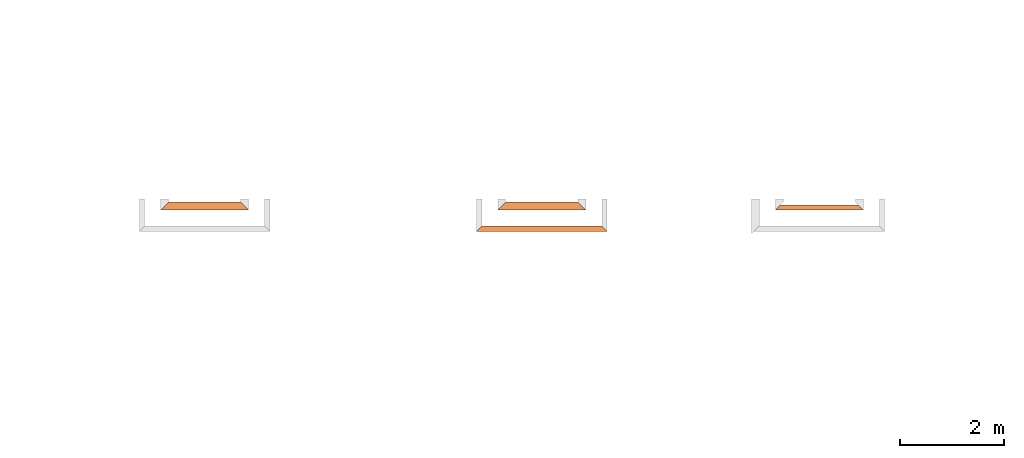
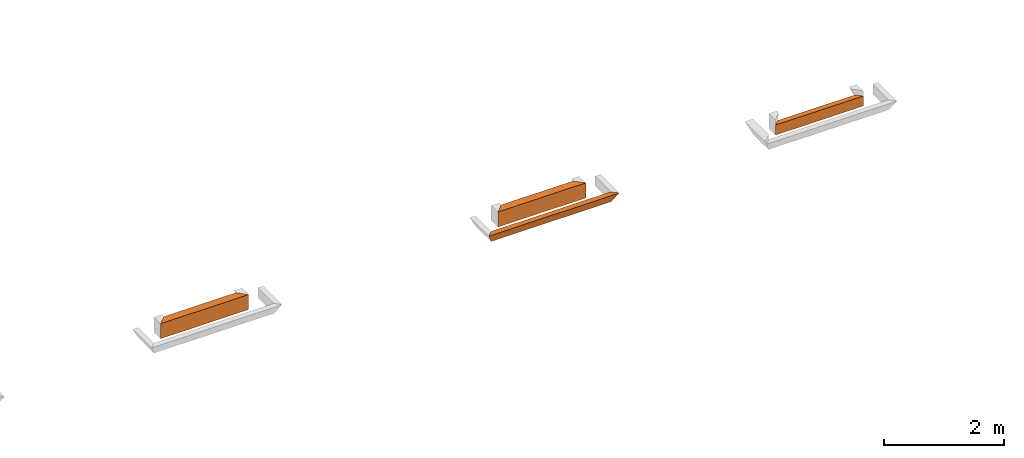
# One storey, part 3 of 8: 4 proxies.
"""IFC4 building model written with IfcOpenShell, lengths in feet."""

from ifc_helpers import new_model, entity, si_unit, converted_unit, derived_unit, direction, frame, origin, place, context, subcontext, project, spatial, type_object, element, save


model = new_model("IFC4")

# Units and contexts
model_context_1 = context("Model", 3, precision=0.0001, world=origin(), true_north=direction((6.12303176911189e-17, 1.0)))
model_context_2 = context("Model", 3, precision=0.0001, world=origin(), true_north=direction((6.12303176911189e-17, 1.0)))
body_context = subcontext(model_context_2, "Body", "Model", "MODEL_VIEW")
ifc_project = project(units=[converted_unit("LENGTHUNIT", "FOOT", entity("IfcRatioMeasure", 0.3048), si_unit("LENGTHUNIT", "METRE"), dimensions=[1, 0, 0, 0, 0, 0, 0]), converted_unit("AREAUNIT", "SQUARE FOOT", entity("IfcRatioMeasure", 0.09290304), si_unit("AREAUNIT", "SQUARE_METRE"), dimensions=[2, 0, 0, 0, 0, 0, 0]), converted_unit("VOLUMEUNIT", "CUBIC FOOT", entity("IfcRatioMeasure", 0.028316846592), si_unit("VOLUMEUNIT", "CUBIC_METRE"), dimensions=[3, 0, 0, 0, 0, 0, 0]), converted_unit("PLANEANGLEUNIT", "DEGREE", entity("IfcRatioMeasure", 0.0174532925199433), si_unit("PLANEANGLEUNIT", "RADIAN"), dimensions=[0, 0, 0, 0, 0, 0, 0]), si_unit("MASSUNIT", "GRAM", prefix="KILO"), derived_unit("MASSDENSITYUNIT", [(si_unit("MASSUNIT", "GRAM", prefix="KILO"), 1), (si_unit("LENGTHUNIT", "METRE"), -3)]), derived_unit("MOMENTOFINERTIAUNIT", [(si_unit("LENGTHUNIT", "METRE"), 4)]), si_unit("TIMEUNIT", "SECOND"), si_unit("FREQUENCYUNIT", "HERTZ"), si_unit("THERMODYNAMICTEMPERATUREUNIT", "DEGREE_CELSIUS"), derived_unit("THERMALTRANSMITTANCEUNIT", [(si_unit("MASSUNIT", "GRAM", prefix="KILO"), 1), (si_unit("THERMODYNAMICTEMPERATUREUNIT", "KELVIN"), -1), (si_unit("TIMEUNIT", "SECOND"), -3)]), derived_unit("VOLUMETRICFLOWRATEUNIT", [(si_unit("LENGTHUNIT", "METRE"), 3), (si_unit("TIMEUNIT", "SECOND"), -1)]), si_unit("ELECTRICCURRENTUNIT", "AMPERE"), si_unit("ELECTRICVOLTAGEUNIT", "VOLT"), si_unit("POWERUNIT", "WATT"), si_unit("FORCEUNIT", "NEWTON"), si_unit("ILLUMINANCEUNIT", "LUX"), si_unit("LUMINOUSFLUXUNIT", "LUMEN"), si_unit("LUMINOUSINTENSITYUNIT", "CANDELA"), derived_unit("USERDEFINED", [(si_unit("MASSUNIT", "GRAM", prefix="KILO"), -1), (si_unit("LENGTHUNIT", "METRE"), -2), (si_unit("TIMEUNIT", "SECOND"), 3), (si_unit("LUMINOUSFLUXUNIT", "LUMEN"), 1)]), derived_unit("LINEARVELOCITYUNIT", [(si_unit("LENGTHUNIT", "METRE"), 1), (si_unit("TIMEUNIT", "SECOND"), -1)]), si_unit("PRESSUREUNIT", "PASCAL"), derived_unit("USERDEFINED", [(si_unit("LENGTHUNIT", "METRE"), -2), (si_unit("MASSUNIT", "GRAM", prefix="KILO"), 1), (si_unit("TIMEUNIT", "SECOND"), -2)]), derived_unit("LINEARFORCEUNIT", [(si_unit("MASSUNIT", "GRAM", prefix="KILO"), 1), (si_unit("LENGTHUNIT", "METRE"), 1), (si_unit("TIMEUNIT", "SECOND"), -2), (si_unit("LENGTHUNIT", "METRE"), -1)]), derived_unit("PLANARFORCEUNIT", [(si_unit("MASSUNIT", "GRAM", prefix="KILO"), 1), (si_unit("LENGTHUNIT", "METRE"), 1), (si_unit("TIMEUNIT", "SECOND"), -2), (si_unit("LENGTHUNIT", "METRE"), -2)])], contexts=[model_context_1])

# Site, building, storey
site_placement = place(None, origin())
site = spatial("IfcSite", under=ifc_project, at=site_placement, CompositionType="ELEMENT")
building_placement = place(site_placement, origin())
building = spatial("IfcBuilding", under=site, at=building_placement, CompositionType="ELEMENT")
storey_placement = place(building_placement, frame((0.0, 0.0, -12.6666666666667)))
storey = spatial("IfcBuildingStorey", under=building, at=storey_placement, Name="BASEMENT", CompositionType="ELEMENT", Elevation=-12.6666666666667)

# Proxies
building_element_proxy_type_1 = type_object("IfcBuildingElementProxyType", PredefinedType="NOTDEFINED")
proxy_1_placement = place(storey_placement, frame((-196.572796069664, 955.897091132648, 11.5833333333333)))
cartesian_point_1 = entity("IfcCartesianPoint", [7.87630257139756, 0.334635416666629, 0.0])
vertex_point_1 = entity("IfcVertexPoint", cartesian_point_1)
cartesian_point_2 = entity("IfcCartesianPoint", [7.87630257139756, 0.334635416666629, 0.669270833333334])
vertex_point_2 = entity("IfcVertexPoint", cartesian_point_2)
ifc_direction_1 = entity("IfcDirection", [0.0, 0.0, 1.0])
edge_curve_1 = entity("IfcEdgeCurve", vertex_point_1, vertex_point_2, entity("IfcTrimmedCurve", entity("IfcLine", cartesian_point_1, entity("IfcVector", ifc_direction_1, 1.0)), [cartesian_point_1], [cartesian_point_2], True, "CARTESIAN"), True)
cartesian_point_3 = entity("IfcCartesianPoint", [8.21093798806413, 0.0, 0.669270833333334])
vertex_point_3 = entity("IfcVertexPoint", cartesian_point_3)
edge_curve_2 = entity("IfcEdgeCurve", vertex_point_2, vertex_point_3, entity("IfcTrimmedCurve", entity("IfcLine", cartesian_point_2, entity("IfcVector", entity("IfcDirection", [0.707106781186488, -0.707106781186608, 0.0]), 1.0)), [cartesian_point_2], [cartesian_point_3], True, "CARTESIAN"), True)
edge_curve_3 = entity("IfcEdgeCurve", vertex_point_3, vertex_point_1, entity("IfcTrimmedCurve", entity("IfcLine", cartesian_point_3, entity("IfcVector", entity("IfcDirection", [-0.408248290463863, 0.408248290463829, -0.816496580927743]), 1.0)), [cartesian_point_3], [cartesian_point_1], True, "CARTESIAN"), True)
cartesian_point_4 = entity("IfcCartesianPoint", [0.334635416666686, 0.33463541666697, 0.0])
vertex_point_4 = entity("IfcVertexPoint", cartesian_point_4)
cartesian_point_5 = entity("IfcCartesianPoint", [0.0, 0.0, 0.669270833333334])
vertex_point_5 = entity("IfcVertexPoint", cartesian_point_5)
edge_curve_4 = entity("IfcEdgeCurve", vertex_point_4, vertex_point_5, entity("IfcTrimmedCurve", entity("IfcLine", cartesian_point_4, entity("IfcVector", entity("IfcDirection", [-0.408248290463863, -0.408248290463829, 0.816496580927743]), 1.0)), [cartesian_point_4], [cartesian_point_5], True, "CARTESIAN"), True)
cartesian_point_6 = entity("IfcCartesianPoint", [0.334635416666686, 0.33463541666697, 0.669270833333334])
vertex_point_6 = entity("IfcVertexPoint", cartesian_point_6)
edge_curve_5 = entity("IfcEdgeCurve", vertex_point_5, vertex_point_6, entity("IfcTrimmedCurve", entity("IfcLine", cartesian_point_5, entity("IfcVector", entity("IfcDirection", [0.707106781186488, 0.707106781186608, 0.0]), 1.0)), [cartesian_point_5], [cartesian_point_6], True, "CARTESIAN"), True)
edge_curve_6 = entity("IfcEdgeCurve", vertex_point_6, vertex_point_4, entity("IfcTrimmedCurve", entity("IfcLine", cartesian_point_6, entity("IfcVector", entity("IfcDirection", [0.0, 0.0, -1.0]), 1.0)), [cartesian_point_6], [cartesian_point_4], True, "CARTESIAN"), True)
ifc_direction_2 = entity("IfcDirection", [-1.0, 0.0, 0.0])
edge_curve_7 = entity("IfcEdgeCurve", vertex_point_1, vertex_point_4, entity("IfcTrimmedCurve", entity("IfcLine", cartesian_point_1, entity("IfcVector", ifc_direction_2, 1.0)), [cartesian_point_1], [cartesian_point_4], True, "CARTESIAN"), True)
cartesian_point_7 = entity("IfcCartesianPoint", [1.33463541666657, 0.33463541666697, 0.669270833333334])
vertex_point_7 = entity("IfcVertexPoint", cartesian_point_7)
ifc_direction_3 = entity("IfcDirection", [1.0, 0.0, 0.0])
edge_curve_8 = entity("IfcEdgeCurve", vertex_point_6, vertex_point_7, entity("IfcTrimmedCurve", entity("IfcLine", cartesian_point_6, entity("IfcVector", ifc_direction_3, 1.0)), [cartesian_point_6], [cartesian_point_7], True, "CARTESIAN"), True)
cartesian_point_8 = entity("IfcCartesianPoint", [2.5846355840587, 0.334635416666856, 0.669270833333334])
vertex_point_8 = entity("IfcVertexPoint", cartesian_point_8)
edge_curve_9 = entity("IfcEdgeCurve", vertex_point_7, vertex_point_8, entity("IfcTrimmedCurve", entity("IfcLine", cartesian_point_7, entity("IfcVector", ifc_direction_3, 1.0)), [cartesian_point_7], [cartesian_point_8], True, "CARTESIAN"), True)
cartesian_point_9 = entity("IfcCartesianPoint", [3.75130225072536, 0.334635416666856, 0.669270833333334])
vertex_point_9 = entity("IfcVertexPoint", cartesian_point_9)
edge_curve_10 = entity("IfcEdgeCurve", vertex_point_8, vertex_point_9, entity("IfcTrimmedCurve", entity("IfcLine", cartesian_point_8, entity("IfcVector", ifc_direction_3, 1.0)), [cartesian_point_8], [cartesian_point_9], True, "CARTESIAN"), True)
cartesian_point_10 = entity("IfcCartesianPoint", [6.87630257139756, 0.334635416666629, 0.669270833333334])
vertex_point_10 = entity("IfcVertexPoint", cartesian_point_10)
edge_curve_11 = entity("IfcEdgeCurve", vertex_point_9, vertex_point_10, entity("IfcTrimmedCurve", entity("IfcLine", cartesian_point_9, entity("IfcVector", ifc_direction_3, 1.0)), [cartesian_point_9], [cartesian_point_10], True, "CARTESIAN"), True)
edge_curve_12 = entity("IfcEdgeCurve", vertex_point_10, vertex_point_2, entity("IfcTrimmedCurve", entity("IfcLine", cartesian_point_10, entity("IfcVector", ifc_direction_3, 1.0)), [cartesian_point_10], [cartesian_point_2], True, "CARTESIAN"), True)
edge_curve_13 = entity("IfcEdgeCurve", vertex_point_3, vertex_point_5, entity("IfcTrimmedCurve", entity("IfcLine", cartesian_point_3, entity("IfcVector", ifc_direction_2, 1.0)), [cartesian_point_3], [cartesian_point_5], True, "CARTESIAN"), True)
element("IfcBuildingElementProxy", 1, at=proxy_1_placement, inside=storey, type_object=building_element_proxy_type_1, PredefinedType="NOTDEFINED", context=body_context, shape_type="AdvancedBrep", body=[
    entity("IfcAdvancedBrep", entity("IfcClosedShell", [entity("IfcAdvancedFace", [entity("IfcFaceOuterBound", entity("IfcEdgeLoop", [entity("IfcOrientedEdge", None, None, edge_curve_1, True), entity("IfcOrientedEdge", None, None, edge_curve_2, True), entity("IfcOrientedEdge", None, None, edge_curve_3, True)]), True)], entity("IfcPlane", entity("IfcAxis2Placement3D", entity("IfcCartesianPoint", [7.87630257139756, 0.334635416666629, 2.0]), entity("IfcDirection", [0.707106781186562, 0.707106781186533, 0.0]), entity("IfcDirection", [-0.707106781186533, 0.707106781186562, 0.0]))), True), entity("IfcAdvancedFace", [entity("IfcFaceOuterBound", entity("IfcEdgeLoop", [entity("IfcOrientedEdge", None, None, edge_curve_4, True), entity("IfcOrientedEdge", None, None, edge_curve_5, True), entity("IfcOrientedEdge", None, None, edge_curve_6, True)]), True)], entity("IfcPlane", entity("IfcAxis2Placement3D", entity("IfcCartesianPoint", [0.334635416666572, 0.334635416666856, 2.0]), entity("IfcDirection", [-0.707106781186548, 0.707106781186548, 0.0]), entity("IfcDirection", [0.707106781186548, 0.707106781186548, 0.0]))), True), entity("IfcAdvancedFace", [entity("IfcFaceOuterBound", entity("IfcEdgeLoop", [entity("IfcOrientedEdge", None, None, edge_curve_7, True), entity("IfcOrientedEdge", None, None, edge_curve_6, False), entity("IfcOrientedEdge", None, None, edge_curve_8, True), entity("IfcOrientedEdge", None, None, edge_curve_9, True), entity("IfcOrientedEdge", None, None, edge_curve_10, True), entity("IfcOrientedEdge", None, None, edge_curve_11, True), entity("IfcOrientedEdge", None, None, edge_curve_12, True), entity("IfcOrientedEdge", None, None, edge_curve_1, False)]), True)], entity("IfcPlane", entity("IfcAxis2Placement3D", cartesian_point_1, entity("IfcDirection", [0.0, 1.0, 0.0]), ifc_direction_2)), True), entity("IfcAdvancedFace", [entity("IfcFaceOuterBound", entity("IfcEdgeLoop", [entity("IfcOrientedEdge", None, None, edge_curve_7, False), entity("IfcOrientedEdge", None, None, edge_curve_3, False), entity("IfcOrientedEdge", None, None, edge_curve_13, True), entity("IfcOrientedEdge", None, None, edge_curve_4, False)]), True)], entity("IfcPlane", entity("IfcAxis2Placement3D", entity("IfcCartesianPoint", [8.37630257139756, -0.165364583333371, 1.0]), entity("IfcDirection", [0.0, -0.894427190999915, -0.447213595499961]), ifc_direction_2)), True), entity("IfcAdvancedFace", [entity("IfcFaceOuterBound", entity("IfcEdgeLoop", [entity("IfcOrientedEdge", None, None, edge_curve_2, False), entity("IfcOrientedEdge", None, None, edge_curve_12, False), entity("IfcOrientedEdge", None, None, edge_curve_11, False), entity("IfcOrientedEdge", None, None, edge_curve_10, False), entity("IfcOrientedEdge", None, None, edge_curve_9, False), entity("IfcOrientedEdge", None, None, edge_curve_8, False), entity("IfcOrientedEdge", None, None, edge_curve_5, False), entity("IfcOrientedEdge", None, None, edge_curve_13, False)]), True)], entity("IfcPlane", entity("IfcAxis2Placement3D", entity("IfcCartesianPoint", [54.8346432586897, 2.96484375000216, 0.669270833333334]), ifc_direction_1, ifc_direction_3)), True)])),
])
building_element_proxy_type_2 = type_object("IfcBuildingElementProxyType", PredefinedType="NOTDEFINED")
proxy_2_placement = place(storey_placement, frame((-177.779827442686, 957.231726549315, 11.5833333333333)))
cartesian_point_11 = entity("IfcCartesianPoint", [5.5416671547116, 0.0, 0.0])
vertex_point_11 = entity("IfcVertexPoint", cartesian_point_11)
cartesian_point_12 = entity("IfcCartesianPoint", [5.21181498777273, 0.329852166938736, 0.659704333877778])
vertex_point_12 = entity("IfcVertexPoint", cartesian_point_12)
edge_curve_14 = entity("IfcEdgeCurve", vertex_point_11, vertex_point_12, entity("IfcTrimmedCurve", entity("IfcLine", cartesian_point_11, entity("IfcVector", entity("IfcDirection", [-0.408248290463861, 0.408248290463826, 0.816496580927745]), 1.0)), [cartesian_point_11], [cartesian_point_12], True, "CARTESIAN"), True)
cartesian_point_13 = entity("IfcCartesianPoint", [5.5416671547116, 0.0, 0.666576254022337])
vertex_point_13 = entity("IfcVertexPoint", cartesian_point_13)
edge_curve_15 = entity("IfcEdgeCurve", vertex_point_12, vertex_point_13, entity("IfcTrimmedCurve", entity("IfcLine", cartesian_point_12, entity("IfcVector", entity("IfcDirection", [0.707030067676022, -0.707030067676022, 0.0147297930765863]), 1.0)), [cartesian_point_12], [cartesian_point_13], True, "CARTESIAN"), True)
edge_curve_16 = entity("IfcEdgeCurve", vertex_point_13, vertex_point_11, entity("IfcTrimmedCurve", entity("IfcLine", cartesian_point_13, entity("IfcVector", entity("IfcDirection", [0.0, 0.0, -1.0]), 1.0)), [cartesian_point_13], [cartesian_point_11], True, "CARTESIAN"), True)
cartesian_point_14 = entity("IfcCartesianPoint", [0.0, 0.0, 0.0])
vertex_point_14 = entity("IfcVertexPoint", cartesian_point_14)
cartesian_point_15 = entity("IfcCartesianPoint", [0.0, 0.0, 0.666576254022335])
vertex_point_15 = entity("IfcVertexPoint", cartesian_point_15)
edge_curve_17 = entity("IfcEdgeCurve", vertex_point_14, vertex_point_15, entity("IfcTrimmedCurve", entity("IfcLine", cartesian_point_14, entity("IfcVector", entity("IfcDirection", [0.0, 0.0, 1.0]), 1.0)), [cartesian_point_14], [cartesian_point_15], True, "CARTESIAN"), True)
cartesian_point_16 = entity("IfcCartesianPoint", [0.329852166938849, 0.329852166938963, 0.659704333877773])
vertex_point_16 = entity("IfcVertexPoint", cartesian_point_16)
edge_curve_18 = entity("IfcEdgeCurve", vertex_point_15, vertex_point_16, entity("IfcTrimmedCurve", entity("IfcLine", cartesian_point_15, entity("IfcVector", entity("IfcDirection", [0.707030067676022, 0.707030067676022, -0.0147297930765841]), 1.0)), [cartesian_point_15], [cartesian_point_16], True, "CARTESIAN"), True)
edge_curve_19 = entity("IfcEdgeCurve", vertex_point_16, vertex_point_14, entity("IfcTrimmedCurve", entity("IfcLine", cartesian_point_16, entity("IfcVector", entity("IfcDirection", [-0.408248290463863, -0.408248290463828, -0.816496580927743]), 1.0)), [cartesian_point_16], [cartesian_point_14], True, "CARTESIAN"), True)
ifc_direction_4 = entity("IfcDirection", [-1.0, 0.0, 0.0])
edge_curve_20 = entity("IfcEdgeCurve", vertex_point_11, vertex_point_14, entity("IfcTrimmedCurve", entity("IfcLine", cartesian_point_11, entity("IfcVector", ifc_direction_4, 1.0)), [cartesian_point_11], [cartesian_point_14], True, "CARTESIAN"), True)
edge_curve_21 = entity("IfcEdgeCurve", vertex_point_16, vertex_point_12, entity("IfcTrimmedCurve", entity("IfcLine", cartesian_point_16, entity("IfcVector", entity("IfcDirection", [1.0, 0.0, 0.0]), 1.0)), [cartesian_point_16], [cartesian_point_12], True, "CARTESIAN"), True)
edge_curve_22 = entity("IfcEdgeCurve", vertex_point_13, vertex_point_15, entity("IfcTrimmedCurve", entity("IfcLine", cartesian_point_13, entity("IfcVector", ifc_direction_4, 1.0)), [cartesian_point_13], [cartesian_point_15], True, "CARTESIAN"), True)
element("IfcBuildingElementProxy", 2, at=proxy_2_placement, inside=storey, type_object=building_element_proxy_type_2, PredefinedType="NOTDEFINED", context=body_context, shape_type="AdvancedBrep", body=[
    entity("IfcAdvancedBrep", entity("IfcClosedShell", [entity("IfcAdvancedFace", [entity("IfcFaceOuterBound", entity("IfcEdgeLoop", [entity("IfcOrientedEdge", None, None, edge_curve_14, True), entity("IfcOrientedEdge", None, None, edge_curve_15, True), entity("IfcOrientedEdge", None, None, edge_curve_16, True)]), True)], entity("IfcPlane", entity("IfcAxis2Placement3D", entity("IfcCartesianPoint", [5.5416671547116, 0.0, 2.0]), entity("IfcDirection", [0.707106781186562, 0.707106781186533, 0.0]), entity("IfcDirection", [-0.707106781186533, 0.707106781186562, 0.0]))), True), entity("IfcAdvancedFace", [entity("IfcFaceOuterBound", entity("IfcEdgeLoop", [entity("IfcOrientedEdge", None, None, edge_curve_17, True), entity("IfcOrientedEdge", None, None, edge_curve_18, True), entity("IfcOrientedEdge", None, None, edge_curve_19, True)]), True)], entity("IfcPlane", entity("IfcAxis2Placement3D", entity("IfcCartesianPoint", [0.0, 0.0, 2.0]), entity("IfcDirection", [-0.707106781186548, 0.707106781186548, 0.0]), entity("IfcDirection", [0.707106781186548, 0.707106781186548, 0.0]))), True), entity("IfcAdvancedFace", [entity("IfcFaceOuterBound", entity("IfcEdgeLoop", [entity("IfcOrientedEdge", None, None, edge_curve_20, True), entity("IfcOrientedEdge", None, None, edge_curve_19, False), entity("IfcOrientedEdge", None, None, edge_curve_21, True), entity("IfcOrientedEdge", None, None, edge_curve_14, False)]), True)], entity("IfcPlane", entity("IfcAxis2Placement3D", cartesian_point_11, entity("IfcDirection", [0.0, 0.894427190999915, -0.447213595499961]), ifc_direction_4)), True), entity("IfcAdvancedFace", [entity("IfcFaceOuterBound", entity("IfcEdgeLoop", [entity("IfcOrientedEdge", None, None, edge_curve_20, False), entity("IfcOrientedEdge", None, None, edge_curve_16, False), entity("IfcOrientedEdge", None, None, edge_curve_22, True), entity("IfcOrientedEdge", None, None, edge_curve_17, False)]), True)], entity("IfcPlane", entity("IfcAxis2Placement3D", entity("IfcCartesianPoint", [5.5416671547116, 0.0, 1.0]), entity("IfcDirection", [0.0, -1.0, 0.0]), ifc_direction_4)), True), entity("IfcAdvancedFace", [entity("IfcFaceOuterBound", entity("IfcEdgeLoop", [entity("IfcOrientedEdge", None, None, edge_curve_15, False), entity("IfcOrientedEdge", None, None, edge_curve_21, False), entity("IfcOrientedEdge", None, None, edge_curve_18, False), entity("IfcOrientedEdge", None, None, edge_curve_22, False)]), True)], entity("IfcPlane", entity("IfcAxis2Placement3D", entity("IfcCartesianPoint", [-75.4583330146403, 0.0, 0.666576254022299]), entity("IfcDirection", [0.0, 0.0208288136818357, 0.999783056728112]), entity("IfcDirection", [0.0, -0.999783056728112, 0.0208288136818357]))), True)])),
])
building_element_proxy_type_3 = type_object("IfcBuildingElementProxyType", PredefinedType="NOTDEFINED")
proxy_3_placement = place(storey_placement, frame((-195.238160652997, 957.231726549315, 11.5833333333333)))
cartesian_point_17 = entity("IfcCartesianPoint", [5.54166715473104, 0.0, 0.0])
vertex_point_17 = entity("IfcVertexPoint", cartesian_point_17)
cartesian_point_18 = entity("IfcCartesianPoint", [5.04166715473104, 0.5, 1.0])
vertex_point_18 = entity("IfcVertexPoint", cartesian_point_18)
edge_curve_23 = entity("IfcEdgeCurve", vertex_point_17, vertex_point_18, entity("IfcTrimmedCurve", entity("IfcLine", cartesian_point_17, entity("IfcVector", entity("IfcDirection", [-0.408248290463864, 0.408248290463864, 0.816496580927725]), 1.0)), [cartesian_point_17], [cartesian_point_18], True, "CARTESIAN"), True)
cartesian_point_19 = entity("IfcCartesianPoint", [5.54166715473104, 0.0, 1.0])
vertex_point_19 = entity("IfcVertexPoint", cartesian_point_19)
edge_curve_24 = entity("IfcEdgeCurve", vertex_point_18, vertex_point_19, entity("IfcTrimmedCurve", entity("IfcLine", cartesian_point_18, entity("IfcVector", entity("IfcDirection", [0.707106781186547, -0.707106781186547, 0.0]), 1.0)), [cartesian_point_18], [cartesian_point_19], True, "CARTESIAN"), True)
cartesian_point_20 = entity("IfcCartesianPoint", [5.54166715473104, 0.0, 0.669270833333334])
vertex_point_20 = entity("IfcVertexPoint", cartesian_point_20)
ifc_direction_5 = entity("IfcDirection", [0.0, 0.0, -1.0])
edge_curve_25 = entity("IfcEdgeCurve", vertex_point_19, vertex_point_20, entity("IfcTrimmedCurve", entity("IfcLine", cartesian_point_19, entity("IfcVector", ifc_direction_5, 1.0)), [cartesian_point_19], [cartesian_point_20], True, "CARTESIAN"), True)
edge_curve_26 = entity("IfcEdgeCurve", vertex_point_20, vertex_point_17, entity("IfcTrimmedCurve", entity("IfcLine", cartesian_point_20, entity("IfcVector", ifc_direction_5, 1.0)), [cartesian_point_20], [cartesian_point_17], True, "CARTESIAN"), True)
cartesian_point_21 = entity("IfcCartesianPoint", [0.499999999999972, 0.500000000000227, 1.0])
vertex_point_21 = entity("IfcVertexPoint", cartesian_point_21)
cartesian_point_22 = entity("IfcCartesianPoint", [0.0, 0.0, 0.0])
vertex_point_22 = entity("IfcVertexPoint", cartesian_point_22)
edge_curve_27 = entity("IfcEdgeCurve", vertex_point_21, vertex_point_22, entity("IfcTrimmedCurve", entity("IfcLine", cartesian_point_21, entity("IfcVector", entity("IfcDirection", [-0.408248290463845, -0.408248290463868, -0.816496580927732]), 1.0)), [cartesian_point_21], [cartesian_point_22], True, "CARTESIAN"), True)
cartesian_point_23 = entity("IfcCartesianPoint", [0.0, 0.0, 0.669270833333334])
vertex_point_23 = entity("IfcVertexPoint", cartesian_point_23)
ifc_direction_6 = entity("IfcDirection", [0.0, 0.0, 1.0])
edge_curve_28 = entity("IfcEdgeCurve", vertex_point_22, vertex_point_23, entity("IfcTrimmedCurve", entity("IfcLine", cartesian_point_22, entity("IfcVector", ifc_direction_6, 1.0)), [cartesian_point_22], [cartesian_point_23], True, "CARTESIAN"), True)
cartesian_point_24 = entity("IfcCartesianPoint", [0.0, 0.0, 1.0])
vertex_point_24 = entity("IfcVertexPoint", cartesian_point_24)
edge_curve_29 = entity("IfcEdgeCurve", vertex_point_23, vertex_point_24, entity("IfcTrimmedCurve", entity("IfcLine", cartesian_point_23, entity("IfcVector", ifc_direction_6, 1.0)), [cartesian_point_23], [cartesian_point_24], True, "CARTESIAN"), True)
edge_curve_30 = entity("IfcEdgeCurve", vertex_point_24, vertex_point_21, entity("IfcTrimmedCurve", entity("IfcLine", cartesian_point_24, entity("IfcVector", entity("IfcDirection", [0.707106781186527, 0.707106781186568, 0.0]), 1.0)), [cartesian_point_24], [cartesian_point_21], True, "CARTESIAN"), True)
ifc_direction_7 = entity("IfcDirection", [-1.0, 0.0, 0.0])
edge_curve_31 = entity("IfcEdgeCurve", vertex_point_17, vertex_point_22, entity("IfcTrimmedCurve", entity("IfcLine", cartesian_point_17, entity("IfcVector", ifc_direction_7, 1.0)), [cartesian_point_17], [cartesian_point_22], True, "CARTESIAN"), True)
ifc_direction_8 = entity("IfcDirection", [1.0, 0.0, 0.0])
edge_curve_32 = entity("IfcEdgeCurve", vertex_point_21, vertex_point_18, entity("IfcTrimmedCurve", entity("IfcLine", cartesian_point_18, entity("IfcVector", ifc_direction_8, 1.0)), [cartesian_point_21], [cartesian_point_18], True, "CARTESIAN"), True)
edge_curve_33 = entity("IfcEdgeCurve", vertex_point_24, vertex_point_19, entity("IfcTrimmedCurve", entity("IfcLine", cartesian_point_19, entity("IfcVector", ifc_direction_8, 1.0)), [cartesian_point_24], [cartesian_point_19], True, "CARTESIAN"), True)
element("IfcBuildingElementProxy", 3, at=proxy_3_placement, inside=storey, type_object=building_element_proxy_type_3, PredefinedType="NOTDEFINED", context=body_context, shape_type="AdvancedBrep", body=[
    entity("IfcAdvancedBrep", entity("IfcClosedShell", [entity("IfcAdvancedFace", [entity("IfcFaceOuterBound", entity("IfcEdgeLoop", [entity("IfcOrientedEdge", None, None, edge_curve_23, True), entity("IfcOrientedEdge", None, None, edge_curve_24, True), entity("IfcOrientedEdge", None, None, edge_curve_25, True), entity("IfcOrientedEdge", None, None, edge_curve_26, True)]), True)], entity("IfcPlane", entity("IfcAxis2Placement3D", entity("IfcCartesianPoint", [5.54166715473104, 0.0, 2.0]), entity("IfcDirection", [0.707106781186562, 0.707106781186533, 0.0]), entity("IfcDirection", [-0.707106781186533, 0.707106781186562, 0.0]))), True), entity("IfcAdvancedFace", [entity("IfcFaceOuterBound", entity("IfcEdgeLoop", [entity("IfcOrientedEdge", None, None, edge_curve_27, True), entity("IfcOrientedEdge", None, None, edge_curve_28, True), entity("IfcOrientedEdge", None, None, edge_curve_29, True), entity("IfcOrientedEdge", None, None, edge_curve_30, True)]), True)], entity("IfcPlane", entity("IfcAxis2Placement3D", entity("IfcCartesianPoint", [0.0, 0.0, 2.0]), entity("IfcDirection", [-0.707106781186548, 0.707106781186548, 0.0]), entity("IfcDirection", [0.707106781186548, 0.707106781186548, 0.0]))), True), entity("IfcAdvancedFace", [entity("IfcFaceOuterBound", entity("IfcEdgeLoop", [entity("IfcOrientedEdge", None, None, edge_curve_23, False), entity("IfcOrientedEdge", None, None, edge_curve_31, True), entity("IfcOrientedEdge", None, None, edge_curve_27, False), entity("IfcOrientedEdge", None, None, edge_curve_32, True)]), True)], entity("IfcPlane", entity("IfcAxis2Placement3D", cartesian_point_17, entity("IfcDirection", [0.0, 0.894427190999915, -0.447213595499961]), ifc_direction_7)), True), entity("IfcAdvancedFace", [entity("IfcFaceOuterBound", entity("IfcEdgeLoop", [entity("IfcOrientedEdge", None, None, edge_curve_24, False), entity("IfcOrientedEdge", None, None, edge_curve_32, False), entity("IfcOrientedEdge", None, None, edge_curve_30, False), entity("IfcOrientedEdge", None, None, edge_curve_33, True)]), True)], entity("IfcPlane", entity("IfcAxis2Placement3D", cartesian_point_18, ifc_direction_6, ifc_direction_7)), True), entity("IfcAdvancedFace", [entity("IfcFaceOuterBound", entity("IfcEdgeLoop", [entity("IfcOrientedEdge", None, None, edge_curve_33, False), entity("IfcOrientedEdge", None, None, edge_curve_29, False), entity("IfcOrientedEdge", None, None, edge_curve_28, False), entity("IfcOrientedEdge", None, None, edge_curve_31, False), entity("IfcOrientedEdge", None, None, edge_curve_26, False), entity("IfcOrientedEdge", None, None, edge_curve_25, False)]), True)], entity("IfcPlane", entity("IfcAxis2Placement3D", cartesian_point_19, entity("IfcDirection", [0.0, -1.0, 0.0]), ifc_direction_7)), True)])),
])
building_element_proxy_type_4 = type_object("IfcBuildingElementProxyType", PredefinedType="NOTDEFINED")
proxy_4_placement = place(storey_placement, frame((-216.446494139458, 957.231726549316, 11.5833333333333)))
cartesian_point_25 = entity("IfcCartesianPoint", [5.54166715472138, 0.0, 0.0])
vertex_point_25 = entity("IfcVertexPoint", cartesian_point_25)
cartesian_point_26 = entity("IfcCartesianPoint", [5.04166715472138, 0.5, 1.0])
vertex_point_26 = entity("IfcVertexPoint", cartesian_point_26)
edge_curve_34 = entity("IfcEdgeCurve", vertex_point_25, vertex_point_26, entity("IfcTrimmedCurve", entity("IfcLine", cartesian_point_25, entity("IfcVector", entity("IfcDirection", [-0.408248290463864, 0.408248290463864, 0.816496580927725]), 1.0)), [cartesian_point_25], [cartesian_point_26], True, "CARTESIAN"), True)
cartesian_point_27 = entity("IfcCartesianPoint", [5.54166715472138, 0.0, 1.0])
vertex_point_27 = entity("IfcVertexPoint", cartesian_point_27)
edge_curve_35 = entity("IfcEdgeCurve", vertex_point_26, vertex_point_27, entity("IfcTrimmedCurve", entity("IfcLine", cartesian_point_26, entity("IfcVector", entity("IfcDirection", [0.707106781186547, -0.707106781186547, 0.0]), 1.0)), [cartesian_point_26], [cartesian_point_27], True, "CARTESIAN"), True)
cartesian_point_28 = entity("IfcCartesianPoint", [5.54166715472138, 0.0, 0.669270833333334])
vertex_point_28 = entity("IfcVertexPoint", cartesian_point_28)
ifc_direction_9 = entity("IfcDirection", [0.0, 0.0, -1.0])
edge_curve_36 = entity("IfcEdgeCurve", vertex_point_27, vertex_point_28, entity("IfcTrimmedCurve", entity("IfcLine", cartesian_point_27, entity("IfcVector", ifc_direction_9, 1.0)), [cartesian_point_27], [cartesian_point_28], True, "CARTESIAN"), True)
edge_curve_37 = entity("IfcEdgeCurve", vertex_point_28, vertex_point_25, entity("IfcTrimmedCurve", entity("IfcLine", cartesian_point_28, entity("IfcVector", ifc_direction_9, 1.0)), [cartesian_point_28], [cartesian_point_25], True, "CARTESIAN"), True)
cartesian_point_29 = entity("IfcCartesianPoint", [0.499999999999972, 0.500000000000227, 1.0])
vertex_point_29 = entity("IfcVertexPoint", cartesian_point_29)
cartesian_point_30 = entity("IfcCartesianPoint", [0.0, 0.0, 0.0])
vertex_point_30 = entity("IfcVertexPoint", cartesian_point_30)
edge_curve_38 = entity("IfcEdgeCurve", vertex_point_29, vertex_point_30, entity("IfcTrimmedCurve", entity("IfcLine", cartesian_point_29, entity("IfcVector", entity("IfcDirection", [-0.408248290463845, -0.408248290463868, -0.816496580927732]), 1.0)), [cartesian_point_29], [cartesian_point_30], True, "CARTESIAN"), True)
cartesian_point_31 = entity("IfcCartesianPoint", [0.0, 0.0, 0.669270833333334])
vertex_point_31 = entity("IfcVertexPoint", cartesian_point_31)
ifc_direction_10 = entity("IfcDirection", [0.0, 0.0, 1.0])
edge_curve_39 = entity("IfcEdgeCurve", vertex_point_30, vertex_point_31, entity("IfcTrimmedCurve", entity("IfcLine", cartesian_point_30, entity("IfcVector", ifc_direction_10, 1.0)), [cartesian_point_30], [cartesian_point_31], True, "CARTESIAN"), True)
cartesian_point_32 = entity("IfcCartesianPoint", [0.0, 0.0, 1.0])
vertex_point_32 = entity("IfcVertexPoint", cartesian_point_32)
edge_curve_40 = entity("IfcEdgeCurve", vertex_point_31, vertex_point_32, entity("IfcTrimmedCurve", entity("IfcLine", cartesian_point_31, entity("IfcVector", ifc_direction_10, 1.0)), [cartesian_point_31], [cartesian_point_32], True, "CARTESIAN"), True)
edge_curve_41 = entity("IfcEdgeCurve", vertex_point_32, vertex_point_29, entity("IfcTrimmedCurve", entity("IfcLine", cartesian_point_32, entity("IfcVector", entity("IfcDirection", [0.707106781186527, 0.707106781186568, 0.0]), 1.0)), [cartesian_point_32], [cartesian_point_29], True, "CARTESIAN"), True)
ifc_direction_11 = entity("IfcDirection", [-1.0, 0.0, 0.0])
edge_curve_42 = entity("IfcEdgeCurve", vertex_point_25, vertex_point_30, entity("IfcTrimmedCurve", entity("IfcLine", cartesian_point_25, entity("IfcVector", ifc_direction_11, 1.0)), [cartesian_point_25], [cartesian_point_30], True, "CARTESIAN"), True)
ifc_direction_12 = entity("IfcDirection", [1.0, 0.0, 0.0])
edge_curve_43 = entity("IfcEdgeCurve", vertex_point_29, vertex_point_26, entity("IfcTrimmedCurve", entity("IfcLine", cartesian_point_26, entity("IfcVector", ifc_direction_12, 1.0)), [cartesian_point_29], [cartesian_point_26], True, "CARTESIAN"), True)
edge_curve_44 = entity("IfcEdgeCurve", vertex_point_32, vertex_point_27, entity("IfcTrimmedCurve", entity("IfcLine", cartesian_point_27, entity("IfcVector", ifc_direction_12, 1.0)), [cartesian_point_32], [cartesian_point_27], True, "CARTESIAN"), True)
element("IfcBuildingElementProxy", 4, at=proxy_4_placement, inside=storey, type_object=building_element_proxy_type_4, PredefinedType="NOTDEFINED", context=body_context, shape_type="AdvancedBrep", body=[
    entity("IfcAdvancedBrep", entity("IfcClosedShell", [entity("IfcAdvancedFace", [entity("IfcFaceOuterBound", entity("IfcEdgeLoop", [entity("IfcOrientedEdge", None, None, edge_curve_34, True), entity("IfcOrientedEdge", None, None, edge_curve_35, True), entity("IfcOrientedEdge", None, None, edge_curve_36, True), entity("IfcOrientedEdge", None, None, edge_curve_37, True)]), True)], entity("IfcPlane", entity("IfcAxis2Placement3D", entity("IfcCartesianPoint", [5.54166715472138, 0.0, 2.0]), entity("IfcDirection", [0.707106781186562, 0.707106781186533, 0.0]), entity("IfcDirection", [-0.707106781186533, 0.707106781186562, 0.0]))), True), entity("IfcAdvancedFace", [entity("IfcFaceOuterBound", entity("IfcEdgeLoop", [entity("IfcOrientedEdge", None, None, edge_curve_38, True), entity("IfcOrientedEdge", None, None, edge_curve_39, True), entity("IfcOrientedEdge", None, None, edge_curve_40, True), entity("IfcOrientedEdge", None, None, edge_curve_41, True)]), True)], entity("IfcPlane", entity("IfcAxis2Placement3D", entity("IfcCartesianPoint", [0.0, 0.0, 2.0]), entity("IfcDirection", [-0.707106781186548, 0.707106781186548, 0.0]), entity("IfcDirection", [0.707106781186548, 0.707106781186548, 0.0]))), True), entity("IfcAdvancedFace", [entity("IfcFaceOuterBound", entity("IfcEdgeLoop", [entity("IfcOrientedEdge", None, None, edge_curve_34, False), entity("IfcOrientedEdge", None, None, edge_curve_42, True), entity("IfcOrientedEdge", None, None, edge_curve_38, False), entity("IfcOrientedEdge", None, None, edge_curve_43, True)]), True)], entity("IfcPlane", entity("IfcAxis2Placement3D", cartesian_point_25, entity("IfcDirection", [0.0, 0.894427190999915, -0.447213595499961]), ifc_direction_11)), True), entity("IfcAdvancedFace", [entity("IfcFaceOuterBound", entity("IfcEdgeLoop", [entity("IfcOrientedEdge", None, None, edge_curve_35, False), entity("IfcOrientedEdge", None, None, edge_curve_43, False), entity("IfcOrientedEdge", None, None, edge_curve_41, False), entity("IfcOrientedEdge", None, None, edge_curve_44, True)]), True)], entity("IfcPlane", entity("IfcAxis2Placement3D", cartesian_point_26, ifc_direction_10, ifc_direction_11)), True), entity("IfcAdvancedFace", [entity("IfcFaceOuterBound", entity("IfcEdgeLoop", [entity("IfcOrientedEdge", None, None, edge_curve_44, False), entity("IfcOrientedEdge", None, None, edge_curve_40, False), entity("IfcOrientedEdge", None, None, edge_curve_39, False), entity("IfcOrientedEdge", None, None, edge_curve_42, False), entity("IfcOrientedEdge", None, None, edge_curve_37, False), entity("IfcOrientedEdge", None, None, edge_curve_36, False)]), True)], entity("IfcPlane", entity("IfcAxis2Placement3D", cartesian_point_27, entity("IfcDirection", [0.0, -1.0, 0.0]), ifc_direction_11)), True)])),
])

save(model, "model.ifc")
